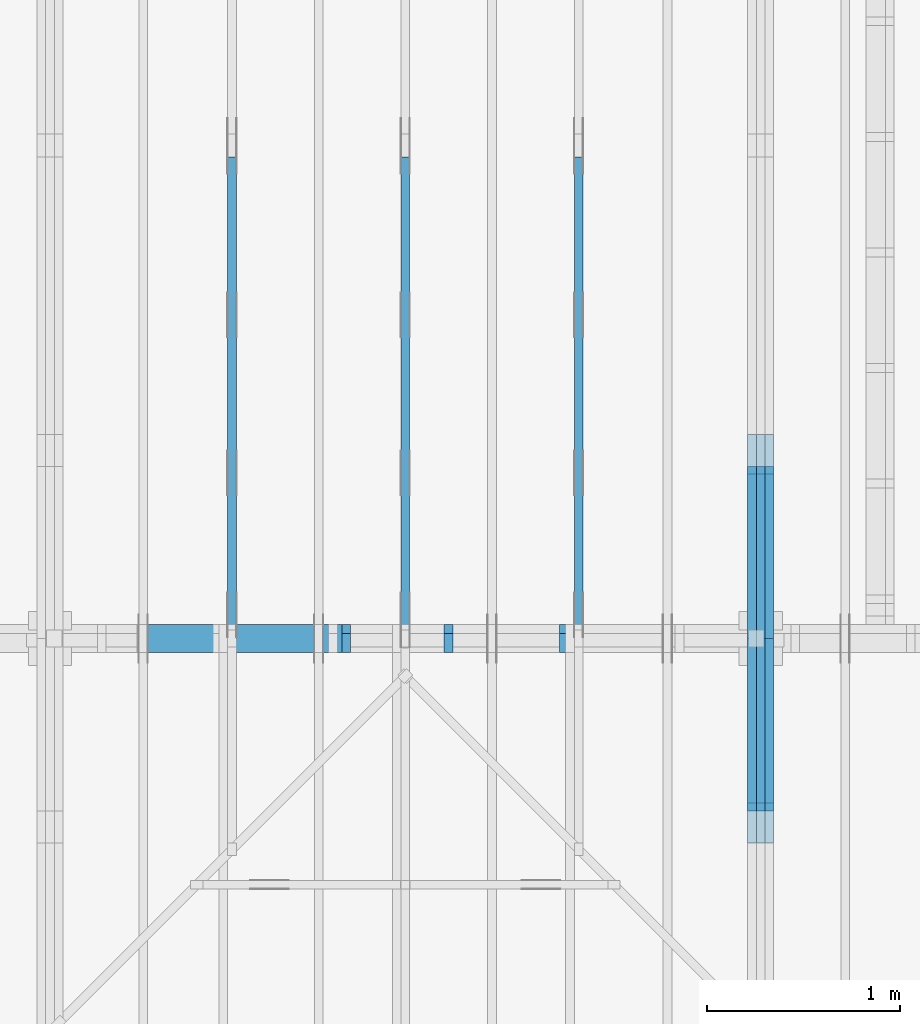
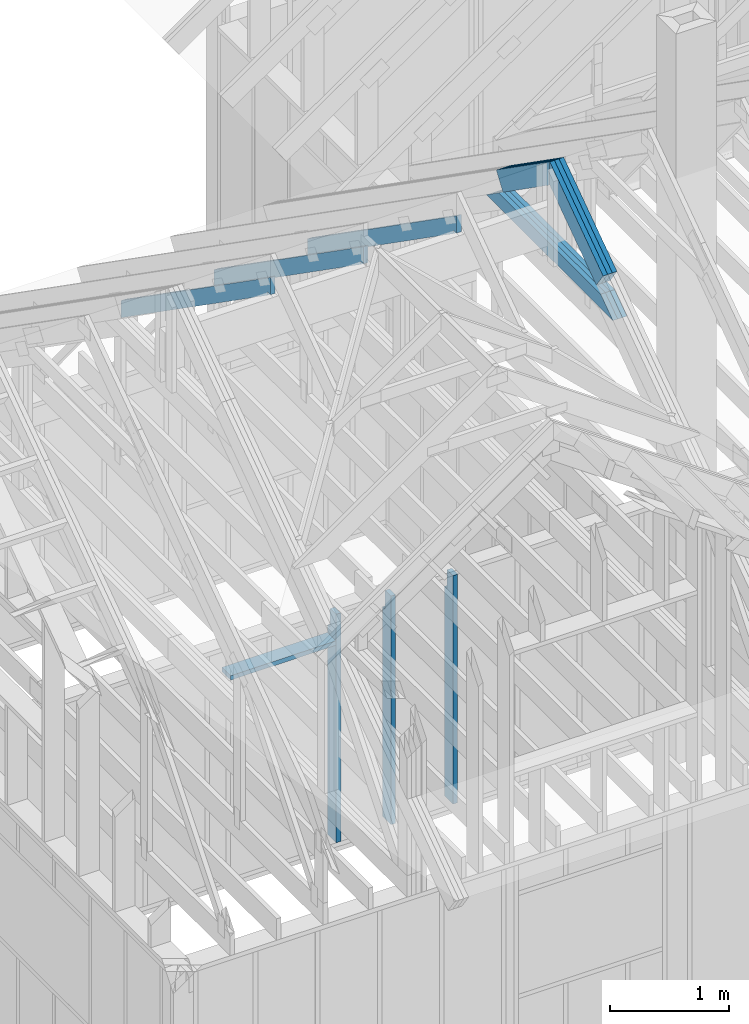
# One storey, part 15 of 70: 16 members, 5 elements without a shape of their own.
"""IFC2X3 building model written with IfcOpenShell, lengths in millimetres."""

from ifc_helpers import new_model, si_unit, frame, origin, origin_with_axes, origin_2d, place, context, project, spatial, faceted_brep, element, aggregate, save


model = new_model("IFC2X3")

# Units and contexts
model_context = context("Model", 3, precision=1e-05, world=origin())
plan_context = context("Plan", 2, precision=1e-05, world=origin_2d())
ifc_project = project(units=[si_unit("LENGTHUNIT", "METRE", prefix="MILLI"), si_unit("AREAUNIT", "SQUARE_METRE"), si_unit("VOLUMEUNIT", "CUBIC_METRE"), si_unit("SOLIDANGLEUNIT", "STERADIAN"), si_unit("PLANEANGLEUNIT", "RADIAN"), si_unit("MASSUNIT", "GRAM"), si_unit("TIMEUNIT", "SECOND"), si_unit("THERMODYNAMICTEMPERATUREUNIT", "DEGREE_CELSIUS"), si_unit("LUMINOUSINTENSITYUNIT", "LUMEN")], contexts=[model_context, plan_context])

# Site, building, storey
site_placement = place(None, origin_with_axes())
site = spatial("IfcSite", under=ifc_project, at=site_placement, CompositionType="ELEMENT")
building_placement = place(site_placement, origin_with_axes())
building = spatial("IfcBuilding", under=site, at=building_placement, Name="Layout 1", CompositionType="ELEMENT")
storey_placement = place(building_placement, origin_with_axes())
storey = spatial("IfcBuildingStorey", under=building, at=storey_placement, Name="Storey 1", CompositionType="ELEMENT", Elevation=0.0)

# Assembly, members
assembly_1_placement = place(storey_placement, frame((5660.000000000293, 8000.0, 9.122500660690286e-13), z_axis=(-1.0, 1.836909530733566e-16, 6.123031769111886e-17), x_axis=(-1.836909530733566e-16, -1.0, 0.0)))
assembly_1 = element("IfcElementAssembly", 1, at=assembly_1_placement, inside=storey, Name="T11", AssemblyPlace="FACTORY", PredefinedType="TRUSS")
member_1_placement = place(assembly_1_placement, frame((3217.6903587327556, 3014.9999999980873, -90.0), z_axis=(0.0, 0.0, 1.0), x_axis=(0.8191520442889916, 0.5735764363510464, 0.0)))
member_1 = element("IfcMember", 2, at=member_1_placement, Name="T18", context=model_context, shape_type="Brep", body=[
    faceted_brep([(1091.564200553914, 195.00000000125283, 45.0), (0.0, 195.00000000125283, 45.0), (8.731149137020111e-11, 0.0, 45.0), (955.0237306050312, 0.0, 45.0), (0.0, 195.00000000125283, 0.0), (1091.564200553914, 195.00000000125283, 1.3367364556033665e-13), (955.0237306050312, 0.0, 1.1695281285500715e-13), (8.731149137020111e-11, 0.0, 1.0692220709365594e-26), (8.731149137020111e-11, 0.0, 0.0), (8.731424673449721e-11, 1.2330791498681715e-27, 45.0), (4.7951469120545665e-14, 195.000000002565, 45.0), (4.5196104824445316e-14, 195.000000002565, -2.7673718568020907e-30), (955.0237306050312, 4.127318893216278e-09, -1.955486371747768e-30), (955.0237306050312, 4.127321648580574e-09, 45.0), (8.73114913702011e-11, 2.7553642961032684e-15, 45.0), (8.731149137020111e-11, 2.9197490389586947e-27, -1.78777161234152e-43), (1091.564200553914, 195.00000000125283, 0.0), (1091.564200553914, 195.00000000125283, 45.0), (955.0237306050312, 4.127286956645548e-09, 45.0), (955.0237306050312, 4.127286956645548e-09, 0.0), (0.0, 195.000000002565, 0.0), (0.0, 195.000000002565, 45.0), (1091.564200553914, 195.00000000125272, 45.0), (1091.564200553914, 195.00000000125272, -6.310887241768095e-30)], [[[0, 1, 2, 3]], [[4, 5, 6, 7]], [[8, 9, 10, 11]], [[12, 13, 14, 15]], [[16, 17, 18, 19]], [[20, 21, 22, 23]]]),
])
member_2_placement = place(assembly_1_placement, frame((3217.6903587327556, 3014.9999999980873, -135.0), z_axis=(0.0, 0.0, 1.0), x_axis=(0.8191520442889916, 0.5735764363510464, 0.0)))
member_2 = element("IfcMember", 3, at=member_2_placement, Name="T18", context=model_context, shape_type="Brep", body=[
    faceted_brep([(1091.564200553914, 195.00000000125283, 45.0), (0.0, 195.00000000125283, 45.0), (8.731149137020111e-11, 0.0, 45.0), (955.0237306050312, 0.0, 45.0), (0.0, 195.00000000125283, 0.0), (1091.564200553914, 195.00000000125283, 1.3367364556033665e-13), (955.0237306050312, 0.0, 1.1695281285500715e-13), (8.731149137020111e-11, 0.0, 1.0692220709365594e-26), (8.731149137020111e-11, 0.0, 0.0), (8.731424673449721e-11, 1.2330791498681715e-27, 45.0), (4.7951469120545665e-14, 195.000000002565, 45.0), (4.5196104824445316e-14, 195.000000002565, -2.7673718568020907e-30), (955.0237306050312, 4.127318893216278e-09, -1.955486371747768e-30), (955.0237306050312, 4.127321648580574e-09, 45.0), (8.73114913702011e-11, 2.7553642961032684e-15, 45.0), (8.731149137020111e-11, 2.9197490389586947e-27, -1.78777161234152e-43), (1091.564200553914, 195.00000000125283, 0.0), (1091.564200553914, 195.00000000125283, 45.0), (955.0237306050312, 4.127286956645548e-09, 45.0), (955.0237306050312, 4.127286956645548e-09, 0.0), (0.0, 195.000000002565, 0.0), (0.0, 195.000000002565, 45.0), (1091.564200553914, 195.00000000125272, 45.0), (1091.564200553914, 195.00000000125272, -6.310887241768095e-30)], [[[0, 1, 2, 3]], [[4, 5, 6, 7]], [[8, 9, 10, 11]], [[12, 13, 14, 15]], [[16, 17, 18, 19]], [[20, 21, 22, 23]]]),
])
member_3_placement = place(assembly_1_placement, frame((3217.6903587327556, 3014.9999999980873, -180.0), z_axis=(0.0, 0.0, 1.0), x_axis=(0.8191520442889916, 0.5735764363510464, 0.0)))
member_3 = element("IfcMember", 4, at=member_3_placement, Name="T18", context=model_context, shape_type="Brep", body=[
    faceted_brep([(1091.564200553914, 195.00000000125283, 45.0), (0.0, 195.00000000125283, 45.0), (8.731149137020111e-11, 0.0, 45.0), (955.0237306050312, 0.0, 45.0), (0.0, 195.00000000125283, 0.0), (1091.564200553914, 195.00000000125283, 1.3367364556033665e-13), (955.0237306050312, 0.0, 1.1695281285500715e-13), (8.731149137020111e-11, 0.0, 1.0692220709365594e-26), (8.731149137020111e-11, 0.0, 0.0), (8.731424673449721e-11, 1.2330791498681715e-27, 45.0), (4.7951469120545665e-14, 195.000000002565, 45.0), (4.5196104824445316e-14, 195.000000002565, -2.7673718568020907e-30), (955.0237306050312, 4.127318893216278e-09, -1.955486371747768e-30), (955.0237306050312, 4.127321648580574e-09, 45.0), (8.73114913702011e-11, 2.7553642961032684e-15, 45.0), (8.731149137020111e-11, 2.9197490389586947e-27, -1.78777161234152e-43), (1091.564200553914, 195.00000000125283, 0.0), (1091.564200553914, 195.00000000125283, 45.0), (955.0237306050312, 4.127286956645548e-09, 45.0), (955.0237306050312, 4.127286956645548e-09, 0.0), (0.0, 195.000000002565, 0.0), (0.0, 195.000000002565, 45.0), (1091.564200553914, 195.00000000125272, 45.0), (1091.564200553914, 195.00000000125272, -6.310887241768095e-30)], [[[0, 1, 2, 3]], [[4, 5, 6, 7]], [[8, 9, 10, 11]], [[12, 13, 14, 15]], [[16, 17, 18, 19]], [[20, 21, 22, 23]]]),
])
member_4_placement = place(assembly_1_placement, frame((3888.1525949105694, 3641.0955042035366, -90.00000000000001), z_axis=(0.0, 0.0, 1.0), x_axis=(0.8191520442889916, -0.5735764363510465, 0.0)))
member_4 = element("IfcMember", 5, at=member_4_placement, Name="T18", context=model_context, shape_type="Brep", body=[
    faceted_brep([(1091.5642005560503, 194.99999999996362, 45.0), (0.0, 194.99999999996362, 45.0), (136.5404699520857, 0.0, 45.0), (1091.5642005561149, 0.0, 45.0), (0.0, 194.99999999996362, 0.0), (1091.5642005560503, 194.99999999996362, 1.336736455605983e-13), (1091.5642005561149, 0.0, 1.336736455606062e-13), (136.5404699520857, 0.0, 1.6720832705721752e-14), (136.54046995208566, -4.263256414560601e-14, 3.1554436208840472e-30), (136.54046995208566, -4.263256414560601e-14, 45.0), (1.4210854715202004e-14, 195.00000000170263, 45.0), (1.4210854715202004e-14, 195.00000000170263, -2.3665827156630354e-30), (1091.5642005561149, 2.0525182992035547e-09, 1.2934457505065866e-29), (1091.5642005561149, 2.0525210545678508e-09, 45.0), (136.5404699520857, -2.3668346958466476e-14, 45.0), (136.5404699520857, -2.6423711254566825e-14, 1.6179322346954286e-30), (1091.5642005561149, 194.99999999996362, 3.950615413346827e-27), (1091.5642005561149, 194.99999999996362, 45.0), (1091.5642005561149, 2.052729541901499e-09, 45.0), (1091.5642005561149, 2.052729541901499e-09, 0.0), (0.0, 195.00000000170257, 0.0), (0.0, 195.00000000170257, 45.0), (1091.5642005560503, 194.9999999999637, 45.0), (1091.5642005560503, 194.9999999999637, 6.310887241768095e-30)], [[[0, 1, 2, 3]], [[4, 5, 6, 7]], [[8, 9, 10, 11]], [[12, 13, 14, 15]], [[16, 17, 18, 19]], [[20, 21, 22, 23]]]),
])
member_5_placement = place(assembly_1_placement, frame((3888.1525949105694, 3641.0955042035366, -135.0), z_axis=(0.0, 0.0, 1.0), x_axis=(0.8191520442889916, -0.5735764363510465, 0.0)))
member_5 = element("IfcMember", 6, at=member_5_placement, Name="T18", context=model_context, shape_type="Brep", body=[
    faceted_brep([(1091.5642005560503, 194.99999999996362, 45.0), (0.0, 194.99999999996362, 45.0), (136.5404699520857, 0.0, 45.0), (1091.5642005561149, 0.0, 45.0), (0.0, 194.99999999996362, 0.0), (1091.5642005560503, 194.99999999996362, 1.336736455605983e-13), (1091.5642005561149, 0.0, 1.336736455606062e-13), (136.5404699520857, 0.0, 1.6720832705721752e-14), (136.54046995208566, -4.263256414560601e-14, 3.1554436208840472e-30), (136.54046995208566, -4.263256414560601e-14, 45.0), (1.4210854715202004e-14, 195.00000000170263, 45.0), (1.4210854715202004e-14, 195.00000000170263, -2.3665827156630354e-30), (1091.5642005561149, 2.0525182992035547e-09, 1.2934457505065866e-29), (1091.5642005561149, 2.0525210545678508e-09, 45.0), (136.5404699520857, -2.3668346958466476e-14, 45.0), (136.5404699520857, -2.6423711254566825e-14, 1.6179322346954286e-30), (1091.5642005561149, 194.99999999996362, 3.950615413346827e-27), (1091.5642005561149, 194.99999999996362, 45.0), (1091.5642005561149, 2.052729541901499e-09, 45.0), (1091.5642005561149, 2.052729541901499e-09, 0.0), (0.0, 195.00000000170257, 0.0), (0.0, 195.00000000170257, 45.0), (1091.5642005560503, 194.9999999999637, 45.0), (1091.5642005560503, 194.9999999999637, 6.310887241768095e-30)], [[[0, 1, 2, 3]], [[4, 5, 6, 7]], [[8, 9, 10, 11]], [[12, 13, 14, 15]], [[16, 17, 18, 19]], [[20, 21, 22, 23]]]),
])
member_6_placement = place(assembly_1_placement, frame((3888.1525949105694, 3641.0955042035366, -180.00000000000003), z_axis=(0.0, 0.0, 1.0), x_axis=(0.8191520442889916, -0.5735764363510465, 0.0)))
member_6 = element("IfcMember", 7, at=member_6_placement, Name="T18", context=model_context, shape_type="Brep", body=[
    faceted_brep([(1091.5642005560503, 194.99999999996362, 45.0), (0.0, 194.99999999996362, 45.0), (136.5404699520857, 0.0, 45.0), (1091.5642005561149, 0.0, 45.0), (0.0, 194.99999999996362, 0.0), (1091.5642005560503, 194.99999999996362, 1.336736455605983e-13), (1091.5642005561149, 0.0, 1.336736455606062e-13), (136.5404699520857, 0.0, 1.6720832705721752e-14), (136.54046995208566, -4.263256414560601e-14, 3.1554436208840472e-30), (136.54046995208566, -4.263256414560601e-14, 45.0), (1.4210854715202004e-14, 195.00000000170263, 45.0), (1.4210854715202004e-14, 195.00000000170263, -2.3665827156630354e-30), (1091.5642005561149, 2.0525182992035547e-09, 1.2934457505065866e-29), (1091.5642005561149, 2.0525210545678508e-09, 45.0), (136.5404699520857, -2.3668346958466476e-14, 45.0), (136.5404699520857, -2.6423711254566825e-14, 1.6179322346954286e-30), (1091.5642005561149, 194.99999999996362, 3.950615413346827e-27), (1091.5642005561149, 194.99999999996362, 45.0), (1091.5642005561149, 2.052729541901499e-09, 45.0), (1091.5642005561149, 2.052729541901499e-09, 0.0), (0.0, 195.00000000170257, 0.0), (0.0, 195.00000000170257, 45.0), (1091.5642005560503, 194.9999999999637, 45.0), (1091.5642005560503, 194.9999999999637, 6.310887241768095e-30)], [[[0, 1, 2, 3]], [[4, 5, 6, 7]], [[8, 9, 10, 11]], [[12, 13, 14, 15]], [[16, 17, 18, 19]], [[20, 21, 22, 23]]]),
])
member_7_placement = place(assembly_1_placement, frame((5060.798502586593, 2964.999999998785, -90.0), z_axis=(0.0, 0.0, 1.0), x_axis=(-1.0, 1.2246063538223773e-16, 0.0)))
member_7 = element("IfcMember", 8, at=member_7_placement, Name="C1", context=model_context, shape_type="Brep", body=[
    faceted_brep([(2121.597005175296, 145.00000000000728, 45.0), (0.0, 145.00000000000728, 45.0), (207.08146097743884, 0.0, 45.0), (1914.5155441979737, 0.0, 45.0), (0.0, 145.00000000000728, 0.0), (2121.597005175296, 145.00000000000728, 2.5981211727881944e-13), (1914.5155441979737, 0.0, 2.3445278999165447e-13), (207.08146097743884, 0.0, 2.5359327287179227e-14), (207.08146097743878, -7.105427357601002e-14, 3.1554436208840472e-30), (207.08146097743878, -7.105427357601002e-14, 45.0), (1.4210854715202004e-14, 145.00000000000728, 45.0), (1.4210854715202004e-14, 145.00000000000728, 0.0), (1914.5155441979737, 7.26803319922997e-12, 4.8521444511629875e-31), (1914.5155441979737, 7.27078856352607e-12, 45.0), (207.08146097743884, 1.898228698049977e-15, 45.0), (207.08146097743884, -8.571355980503717e-16, 5.248268497299439e-32), (2121.597005175296, 145.00000000000728, 0.0), (2121.597005175296, 145.00000000000728, 45.0), (1914.515544197974, 7.389644451905042e-12, 45.0), (1914.515544197974, 7.389644451905042e-12, 1.262177448353619e-29), (0.0, 145.00000000000728, 0.0), (-1.6871183120499046e-31, 145.00000000000728, 45.0), (2121.597005175296, 145.00000000000713, 45.0), (2121.597005175296, 145.00000000000713, -7.888609052210118e-30)], [[[0, 1, 2, 3]], [[4, 5, 6, 7]], [[8, 9, 10, 11]], [[12, 13, 14, 15]], [[16, 17, 18, 19]], [[20, 21, 22, 23]]]),
])
member_8_placement = place(assembly_1_placement, frame((5060.798502586593, 2964.999999998785, -135.0), z_axis=(0.0, 0.0, 1.0), x_axis=(-1.0, 1.2246063538223773e-16, 0.0)))
member_8 = element("IfcMember", 9, at=member_8_placement, Name="C1", context=model_context, shape_type="Brep", body=[
    faceted_brep([(2121.597005175296, 145.00000000000728, 45.0), (0.0, 145.00000000000728, 45.0), (207.08146097743884, 0.0, 45.0), (1914.5155441979737, 0.0, 45.0), (0.0, 145.00000000000728, 0.0), (2121.597005175296, 145.00000000000728, 2.5981211727881944e-13), (1914.5155441979737, 0.0, 2.3445278999165447e-13), (207.08146097743884, 0.0, 2.5359327287179227e-14), (207.08146097743878, -7.105427357601002e-14, 3.1554436208840472e-30), (207.08146097743878, -7.105427357601002e-14, 45.0), (1.4210854715202004e-14, 145.00000000000728, 45.0), (1.4210854715202004e-14, 145.00000000000728, 0.0), (1914.5155441979737, 7.26803319922997e-12, 4.8521444511629875e-31), (1914.5155441979737, 7.27078856352607e-12, 45.0), (207.08146097743884, 1.898228698049977e-15, 45.0), (207.08146097743884, -8.571355980503717e-16, 5.248268497299439e-32), (2121.597005175296, 145.00000000000728, 0.0), (2121.597005175296, 145.00000000000728, 45.0), (1914.515544197974, 7.389644451905042e-12, 45.0), (1914.515544197974, 7.389644451905042e-12, 1.262177448353619e-29), (0.0, 145.00000000000728, 0.0), (-1.6871183120499046e-31, 145.00000000000728, 45.0), (2121.597005175296, 145.00000000000713, 45.0), (2121.597005175296, 145.00000000000713, -7.888609052210118e-30)], [[[0, 1, 2, 3]], [[4, 5, 6, 7]], [[8, 9, 10, 11]], [[12, 13, 14, 15]], [[16, 17, 18, 19]], [[20, 21, 22, 23]]]),
])
member_9_placement = place(assembly_1_placement, frame((5060.798502586593, 2964.999999998785, -180.0), z_axis=(0.0, 0.0, 1.0), x_axis=(-1.0, 1.2246063538223773e-16, 0.0)))
member_9 = element("IfcMember", 10, at=member_9_placement, Name="C1", context=model_context, shape_type="Brep", body=[
    faceted_brep([(2121.597005175296, 145.00000000000728, 45.0), (0.0, 145.00000000000728, 45.0), (207.08146097743884, 0.0, 45.0), (1914.5155441979737, 0.0, 45.0), (0.0, 145.00000000000728, 0.0), (2121.597005175296, 145.00000000000728, 2.5981211727881944e-13), (1914.5155441979737, 0.0, 2.3445278999165447e-13), (207.08146097743884, 0.0, 2.5359327287179227e-14), (207.08146097743878, -7.105427357601002e-14, 3.1554436208840472e-30), (207.08146097743878, -7.105427357601002e-14, 45.0), (1.4210854715202004e-14, 145.00000000000728, 45.0), (1.4210854715202004e-14, 145.00000000000728, 0.0), (1914.5155441979737, 7.26803319922997e-12, 4.8521444511629875e-31), (1914.5155441979737, 7.27078856352607e-12, 45.0), (207.08146097743884, 1.898228698049977e-15, 45.0), (207.08146097743884, -8.571355980503717e-16, 5.248268497299439e-32), (2121.597005175296, 145.00000000000728, 0.0), (2121.597005175296, 145.00000000000728, 45.0), (1914.515544197974, 7.389644451905042e-12, 45.0), (1914.515544197974, 7.389644451905042e-12, 1.262177448353619e-29), (0.0, 145.00000000000728, 0.0), (-1.6871183120499046e-31, 145.00000000000728, 45.0), (2121.597005175296, 145.00000000000713, 45.0), (2121.597005175296, 145.00000000000713, -7.888609052210118e-30)], [[[0, 1, 2, 3]], [[4, 5, 6, 7]], [[8, 9, 10, 11]], [[12, 13, 14, 15]], [[16, 17, 18, 19]], [[20, 21, 22, 23]]]),
])
aggregate(assembly_1, [member_1, member_2, member_3, member_4, member_5, member_6, member_7, member_8, member_9])

assembly_2_placement = place(storey_placement, frame((-48.55339059327651, 3927.500000000001, -2470.0), z_axis=(0.0, -1.0, 6.123031769111886e-17), x_axis=(1.0, 0.0, 0.0)))
assembly_2 = element("IfcElementAssembly", 11, at=assembly_2_placement, inside=storey, Name="VE8", AssemblyPlace="FACTORY", PredefinedType="NOTDEFINED")
member_10_placement = place(assembly_2_placement, frame((4177.5000000018335, 2425.0, -145.00000000000003), z_axis=(0.0, 0.0, 1.0), x_axis=(-1.836909530733566e-16, -1.0, 0.0)))
member_10 = element("IfcMember", 12, at=member_10_placement, Name="S42", context=model_context, shape_type="Brep", body=[
    faceted_brep([(0.0, 45.00000000001455, 45.00000000000003), (195.00000000186265, 45.00000000001455, 45.00000000000005), (195.00000000186265, 0.0, 45.00000000000005), (0.0, 0.0, 45.00000000000003), (195.00000000186265, -2.1311460639909362e-46, 2.842170943040401e-14), (195.00000000186265, -3.3742366240998114e-31, 45.00000000000003), (195.00000000186265, 45.00000000001182, 45.00000000000003), (195.00000000186265, 45.00000000001182, 2.842170943040401e-14), (2.7553642961003504e-15, -3.3742366240998114e-31, 45.00000000000003), (8.878396065212235e-15, -1.0872540233210496e-30, 145.0), (1.4389124657414716e-14, 45.00000000001455, 145.00000000000003), (8.26609288830283e-15, 45.00000000001455, 45.00000000000003), (2335.0, -4.2891837542628763e-13, 2.842170943040403e-14), (2335.0, -4.200399793610754e-13, 145.00000000000003), (1.6308810349815748e-30, 8.878396065212237e-15, 145.00000000000003), (5.061354936149717e-31, 2.7553642961003504e-15, 45.00000000000003), (195.00000000186265, -3.306437155354634e-14, 45.00000000000003), (195.00000000186265, -3.5819735849646686e-14, 2.842170943040401e-14), (-1.6871183120499057e-31, 45.00000000001182, 45.00000000000003), (-5.436270116605249e-31, 45.000000000011816, 145.00000000000003), (2335.0, 45.000000000011674, 145.00000000000003), (2335.0, 45.00000000001168, 2.8421709430403998e-14), (195.00000000186265, 45.00000000001181, 2.8421709430404004e-14), (195.00000000186265, 45.00000000001181, 45.00000000000003), (2335.0, 44.99999999998545, 0.0), (2335.0, 44.99999999998545, 145.00000000000003), (2335.0, 0.0, 145.00000000000003), (2335.0, 0.0, 0.0), (2335.0, 44.99999999998545, 145.00000000000003), (0.0, 44.99999999998545, 145.00000000000003), (0.0, 0.0, 145.00000000000003), (2335.0, 0.0, 145.00000000000003), (195.00000000186265, 45.00000000001182, 5.2301533330168465e-14), (2335.0, 45.00000000001182, 3.143672930479291e-13), (2335.0, 0.0, 3.143672930479291e-13), (195.00000000186265, 0.0, 5.2301533330168465e-14)], [[[0, 1, 2, 3]], [[4, 5, 6, 7]], [[8, 9, 10, 11]], [[12, 13, 14, 15, 16, 17]], [[18, 19, 20, 21, 22, 23]], [[24, 25, 26, 27]], [[28, 29, 30, 31]], [[32, 33, 34, 35]]]),
])
member_11_placement = place(assembly_2_placement, frame((4777.5000000018335, 2425.0, -145.00000000000003), z_axis=(0.0, 0.0, 1.0), x_axis=(-1.836909530733566e-16, -1.0, 0.0)))
member_11 = element("IfcMember", 13, at=member_11_placement, Name="S42", context=model_context, shape_type="Brep", body=[
    faceted_brep([(0.0, 45.0, 45.00000000000003), (195.00000000186265, 45.0, 45.00000000000005), (195.00000000186265, 1.4551915228366852e-11, 45.00000000000005), (0.0, 1.4551915228366852e-11, 45.00000000000003), (195.00000000186265, 1.3642420526593924e-11, 2.842170943040401e-14), (195.00000000186265, 1.3642420526593924e-11, 45.00000000000003), (195.00000000186265, 44.99999999999909, 45.00000000000003), (195.00000000186265, 44.99999999999909, 2.842170943040401e-14), (2.7553642961021324e-15, 1.4551915228366852e-11, 45.00000000000003), (8.878396065214018e-15, 1.4551915228366852e-11, 145.00000000000003), (1.4389124657412933e-14, 45.0, 145.00000000000003), (8.266092888301048e-15, 45.0, 45.00000000000003), (2335.0, 1.4122996852940564e-11, 2.842170943040403e-14), (2335.0, 1.4131875249005776e-11, 145.00000000000003), (1.6308810349815748e-30, 1.4560793624432064e-11, 145.00000000000003), (5.061354936149717e-31, 1.4554670592662952e-11, 45.00000000000003), (195.00000000186265, 1.4518850856813305e-11, 45.00000000000003), (195.00000000186265, 1.4516095492517205e-11, 2.8421709430404014e-14), (-1.6871183120499057e-31, 44.99999999999909, 45.00000000000003), (-5.436270116605249e-31, 44.99999999999908, 145.00000000000003), (2335.0, 44.99999999999894, 145.00000000000003), (2335.0, 44.99999999999895, 2.8421709430403998e-14), (195.00000000186265, 44.999999999999076, 2.8421709430404004e-14), (195.00000000186265, 44.999999999999076, 45.00000000000003), (2335.0, 44.99999999998545, 0.0), (2335.0, 44.99999999998545, 145.00000000000003), (2335.0, 0.0, 145.00000000000003), (2335.0, 0.0, 0.0), (2335.0, 44.99999999998545, 145.00000000000003), (0.0, 44.99999999998545, 145.00000000000003), (0.0, 1.4551915228366852e-11, 145.00000000000003), (2335.0, 1.4551915228366852e-11, 145.00000000000003), (195.00000000186265, 44.99999999999909, 5.2301533330168465e-14), (2335.0, 44.99999999999909, 3.143672930479291e-13), (2335.0, 0.0, 3.143672930479291e-13), (195.00000000186265, 0.0, 5.2301533330168465e-14)], [[[0, 1, 2, 3]], [[4, 5, 6, 7]], [[8, 9, 10, 11]], [[12, 13, 14, 15, 16, 17]], [[18, 19, 20, 21, 22, 23]], [[24, 25, 26, 27]], [[28, 29, 30, 31]], [[32, 33, 34, 35]]]),
])
member_12_placement = place(assembly_2_placement, frame((3647.3033905951015, 2425.0, -145.0), z_axis=(0.0, 0.0, 1.0), x_axis=(-1.836909530733566e-16, -1.0, 0.0)))
member_12 = element("IfcMember", 14, at=member_12_placement, Name="S42", context=model_context, shape_type="Brep", body=[
    faceted_brep([(0.0, 45.00000000001455, 45.0), (195.00000000186265, 45.00000000001455, 45.00000000000002), (195.00000000186265, 0.0, 45.00000000000002), (0.0, 0.0, 45.0), (195.00000000186265, 0.0, 0.0), (195.00000000186265, -3.3742366240998092e-31, 45.0), (195.00000000186265, 45.00000000001455, 45.0), (195.00000000186265, 45.00000000001455, 0.0), (2.755364296100349e-15, -3.3742366240998092e-31, 45.0), (8.878396065212235e-15, -1.0872540233210496e-30, 145.0), (1.4389124657414716e-14, 45.00000000001455, 145.0), (8.26609288830283e-15, 45.00000000001455, 45.0), (2335.0, -4.2891837542628763e-13, 2.626280839091018e-29), (2335.0, -4.200399793610754e-13, 145.0), (1.6308810349815745e-30, 8.878396065212235e-15, 145.0), (5.061354936149714e-31, 2.755364296100349e-15, 45.0), (195.00000000186265, -3.306437155354634e-14, 45.0), (195.00000000186265, -3.5819735849646686e-14, 2.193253805685826e-30), (-1.6871183120499046e-31, 45.00000000001455, 45.0), (-5.436270116605248e-31, 45.000000000014545, 145.0), (2335.0, 45.0000000000144, 145.0), (2335.0, 45.00000000001441, -8.67746995743113e-30), (195.00000000186265, 45.00000000001454, -7.888609052210118e-31), (195.00000000186265, 45.00000000001454, 45.0), (2335.0, 45.00000000001501, 2.842170943040401e-14), (2335.0, 45.00000000001501, 145.0), (2335.0, 4.547473508864641e-13, 145.0), (2335.0, 4.547473508864641e-13, 2.842170943040401e-14), (2335.0, 45.00000000001501, 145.0), (0.0, 45.00000000001501, 145.0), (0.0, 0.0, 145.0), (2335.0, 0.0, 145.0), (195.00000000186265, 45.00000000001455, 2.3879823899764457e-14), (2335.0, 45.00000000001455, 2.859455836175251e-13), (2335.0, 4.547473508864641e-13, 2.859455836175251e-13), (195.00000000186265, 4.547473508864641e-13, 2.3879823899764457e-14)], [[[0, 1, 2, 3]], [[4, 5, 6, 7]], [[8, 9, 10, 11]], [[12, 13, 14, 15, 16, 17]], [[18, 19, 20, 21, 22, 23]], [[24, 25, 26, 27]], [[28, 29, 30, 31]], [[32, 33, 34, 35]]]),
])
member_13_placement = place(assembly_2_placement, frame((3647.3033905932766, 2154.9999999987776, -145.0), z_axis=(0.0, 0.0, 1.0), x_axis=(-1.0, 1.2246063538223773e-16, 0.0)))
member_13 = element("IfcMember", 15, at=member_13_placement, Name="S45", context=model_context, shape_type="Brep", body=[
    faceted_brep([(1020.0, 45.00000000001455, 145.0), (0.0, 45.00000000001455, 145.0), (0.0, 0.0, 145.0), (1020.0, 0.0, 145.0), (0.0, 45.00000000001455, 0.0), (1020.0, 45.00000000001455, 1.2490984808988248e-13), (1020.0, 0.0, 1.2490984808988248e-13), (0.0, 0.0, 0.0), (0.0, 0.0, 0.0), (8.878396065212235e-15, -1.0872540233210496e-30, 145.0), (1.4389124657414716e-14, 45.00000000001455, 145.0), (5.51072859220248e-15, 45.00000000001455, -3.3742366241009005e-31), (1020.0, -1.8736477213482372e-13, 1.1472404521939351e-29), (1020.0, -1.7848637606961149e-13, 145.0), (1.6308810349815745e-30, 8.878396065212235e-15, 145.0), (0.0, 0.0, 0.0), (1020.0, 45.00000000001455, 0.0), (1020.0, 45.00000000001455, 145.0), (1020.0, 0.0, 145.0), (1020.0, 0.0, 0.0), (-1.2154326714572542e-63, 45.00000000001455, 0.0), (-5.436270116605248e-31, 45.000000000014545, 145.0), (1020.0, 45.00000000001448, 145.0), (1020.0, 45.00000000001449, -3.944304526105059e-30)], [[[0, 1, 2, 3]], [[4, 5, 6, 7]], [[8, 9, 10, 11]], [[12, 13, 14, 15]], [[16, 17, 18, 19]], [[20, 21, 22, 23]]]),
])
aggregate(assembly_2, [member_10, member_11, member_12, member_13])

# Assembly, member
assembly_3_placement = place(storey_placement, frame((4805.0, 8000.000000000001, -4.5336966873841394e-13), z_axis=(-1.0, 1.836909530733566e-16, 6.123031769111886e-17), x_axis=(-1.836909530733566e-16, -1.0, 0.0)))
assembly_3 = element("IfcElementAssembly", 16, at=assembly_3_placement, inside=storey, Name="T1", AssemblyPlace="FACTORY", PredefinedType="TRUSS")
member_14_placement = place(assembly_3_placement, frame((1500.0000000016166, 1635.2479471356055, -45.00000000000001), z_axis=(0.0, 0.0, 1.0), x_axis=(0.819152044289039, 0.5735764363509788, 0.0)))
member_14 = element("IfcMember", 17, at=member_14_placement, Name="SC1", context=model_context, shape_type="Brep", body=[
    faceted_brep([(3153.466564941884, 145.00000000001808, 45.0), (101.53009304063289, 145.00000000001808, 45.0), (0.0, 0.0, 45.0), (2993.339291642151, 0.0, 45.0), (3012.6171737768436, 27.53166894659796, 45.0), (3051.9364719027108, 0.0, 45.0), (101.53009304063289, 145.00000000001808, 1.2433439704173617e-14), (3153.466564941884, 145.00000000001808, 3.861755191994257e-13), (3051.9364719027108, 0.0, 3.737420794954309e-13), (3012.6171737768436, 27.53166894659796, 3.6892701326415355e-13), (2993.339291642151, 0.0, 3.665662315691152e-13), (0.0, 0.0, 0.0), (101.53009304063289, 144.99999999999397, 0.0), (101.53009304063289, 144.99999999999397, 45.0), (3153.466564941884, 145.0000000000182, 45.0), (3153.466564941884, 145.0000000000182, 6.310887241768095e-30), (1.1640850691042934e-14, -8.151011405060374e-15, -8.701351488741532e-31), (1.3897912986952758e-14, -9.731423438868915e-15, 45.0), (101.53009304063293, 144.99999999999397, 45.0), (101.53009304063293, 144.99999999999397, -2.4478569593161768e-30), (2993.339291642151, 1.7222354970193538e-09, -4.137414620662534e-29), (2993.339291642151, 1.7222382523836499e-09, 45.0), (-1.5853151733295292e-27, 2.755364296100349e-15, 45.0), (0.0, 0.0, 0.0), (3012.6171737768445, 27.53166894659762, 7.573064690121713e-29), (3012.6171737768445, 27.53166894659762, 45.0), (2993.3392916421517, 1.7212187231052667e-09, 45.0), (2993.3392916421517, 1.7212187231052667e-09, 7.573064690121713e-29), (3051.9364719027103, 1.754870027070865e-09, 6.310887241768094e-29), (3051.9364719027103, 1.754870027070865e-09, 45.0), (3012.617173776843, 27.531668946597165, 45.0), (3012.617173776843, 27.531668946597165, 6.310887241768094e-29), (3153.4665649418857, 145.0000000000175, 1.0097419586828951e-28), (3153.4665649418857, 145.0000000000175, 45.0), (3051.936471902712, 1.7550974007463083e-09, 45.0), (3051.936471902712, 1.7550974007463083e-09, 1.0097419586828951e-28)], [[[0, 1, 2, 3, 4, 5]], [[6, 7, 8, 9, 10, 11]], [[12, 13, 14, 15]], [[16, 17, 18, 19]], [[20, 21, 22, 23]], [[24, 25, 26, 27]], [[28, 29, 30, 31]], [[32, 33, 34, 35]]]),
])
aggregate(assembly_3, [member_14])

assembly_4_placement = place(storey_placement, frame((3905.0000000000005, 8000.000000000001, -4.5336966873841394e-13), z_axis=(-1.0, 1.836909530733566e-16, 6.123031769111886e-17), x_axis=(-1.836909530733566e-16, -1.0, 0.0)))
assembly_4 = element("IfcElementAssembly", 18, at=assembly_4_placement, inside=storey, Name="T1", AssemblyPlace="FACTORY", PredefinedType="TRUSS")
member_15_placement = place(assembly_4_placement, frame((1500.0000000016166, 1635.2479471356055, -45.00000000000001), z_axis=(0.0, 0.0, 1.0), x_axis=(0.819152044289039, 0.5735764363509788, 0.0)))
member_15 = element("IfcMember", 19, at=member_15_placement, Name="SC1", context=model_context, shape_type="Brep", body=[
    faceted_brep([(3153.466564941884, 145.00000000001808, 45.0), (101.53009304063289, 145.00000000001808, 45.0), (0.0, 0.0, 45.0), (2993.339291642151, 0.0, 45.0), (3012.6171737768436, 27.53166894659796, 45.0), (3051.9364719027108, 0.0, 45.0), (101.53009304063289, 145.00000000001808, 1.2433439704173617e-14), (3153.466564941884, 145.00000000001808, 3.861755191994257e-13), (3051.9364719027108, 0.0, 3.737420794954309e-13), (3012.6171737768436, 27.53166894659796, 3.6892701326415355e-13), (2993.339291642151, 0.0, 3.665662315691152e-13), (0.0, 0.0, 0.0), (101.53009304063289, 144.99999999999397, 0.0), (101.53009304063289, 144.99999999999397, 45.0), (3153.466564941884, 145.0000000000182, 45.0), (3153.466564941884, 145.0000000000182, 6.310887241768095e-30), (1.1640850691042934e-14, -8.151011405060374e-15, -8.701351488741532e-31), (1.3897912986952758e-14, -9.731423438868915e-15, 45.0), (101.53009304063293, 144.99999999999397, 45.0), (101.53009304063293, 144.99999999999397, -2.4478569593161768e-30), (2993.339291642151, 1.7222354970193538e-09, -4.137414620662534e-29), (2993.339291642151, 1.7222382523836499e-09, 45.0), (-1.5853151733295292e-27, 2.755364296100349e-15, 45.0), (0.0, 0.0, 0.0), (3012.6171737768445, 27.53166894659762, 7.573064690121713e-29), (3012.6171737768445, 27.53166894659762, 45.0), (2993.3392916421517, 1.7212187231052667e-09, 45.0), (2993.3392916421517, 1.7212187231052667e-09, 7.573064690121713e-29), (3051.9364719027103, 1.754870027070865e-09, 6.310887241768094e-29), (3051.9364719027103, 1.754870027070865e-09, 45.0), (3012.617173776843, 27.531668946597165, 45.0), (3012.617173776843, 27.531668946597165, 6.310887241768094e-29), (3153.4665649418857, 145.0000000000175, 1.0097419586828951e-28), (3153.4665649418857, 145.0000000000175, 45.0), (3051.936471902712, 1.7550974007463083e-09, 45.0), (3051.936471902712, 1.7550974007463083e-09, 1.0097419586828951e-28)], [[[0, 1, 2, 3, 4, 5]], [[6, 7, 8, 9, 10, 11]], [[12, 13, 14, 15]], [[16, 17, 18, 19]], [[20, 21, 22, 23]], [[24, 25, 26, 27]], [[28, 29, 30, 31]], [[32, 33, 34, 35]]]),
])
aggregate(assembly_4, [member_15])

assembly_5_placement = place(storey_placement, frame((3005.0000000000005, 8000.0, 1.3776821480501744e-15), z_axis=(-1.0, 1.836909530733566e-16, 6.123031769111886e-17), x_axis=(-1.836909530733566e-16, -1.0, 0.0)))
assembly_5 = element("IfcElementAssembly", 20, at=assembly_5_placement, inside=storey, Name="T1", AssemblyPlace="FACTORY", PredefinedType="TRUSS")
member_16_placement = place(assembly_5_placement, frame((1500.0000000016166, 1635.2479471356055, -45.00000000000001), z_axis=(0.0, 0.0, 1.0), x_axis=(0.819152044289039, 0.5735764363509788, 0.0)))
member_16 = element("IfcMember", 21, at=member_16_placement, Name="SC1", context=model_context, shape_type="Brep", body=[
    faceted_brep([(3153.466564941884, 145.00000000001808, 45.0), (101.53009304063289, 145.00000000001808, 45.0), (0.0, 0.0, 45.0), (2993.339291642151, 0.0, 45.0), (3012.6171737768436, 27.53166894659796, 45.0), (3051.9364719027108, 0.0, 45.0), (101.53009304063289, 145.00000000001808, 1.2433439704173617e-14), (3153.466564941884, 145.00000000001808, 3.861755191994257e-13), (3051.9364719027108, 0.0, 3.737420794954309e-13), (3012.6171737768436, 27.53166894659796, 3.6892701326415355e-13), (2993.339291642151, 0.0, 3.665662315691152e-13), (0.0, 0.0, 0.0), (101.53009304063289, 144.99999999999397, 0.0), (101.53009304063289, 144.99999999999397, 45.0), (3153.466564941884, 145.0000000000182, 45.0), (3153.466564941884, 145.0000000000182, 6.310887241768095e-30), (1.1640850691042934e-14, -8.151011405060374e-15, -8.701351488741532e-31), (1.3897912986952758e-14, -9.731423438868915e-15, 45.0), (101.53009304063293, 144.99999999999397, 45.0), (101.53009304063293, 144.99999999999397, -2.4478569593161768e-30), (2993.339291642151, 1.7222354970193538e-09, -4.137414620662534e-29), (2993.339291642151, 1.7222382523836499e-09, 45.0), (-1.5853151733295292e-27, 2.755364296100349e-15, 45.0), (0.0, 0.0, 0.0), (3012.6171737768445, 27.53166894659762, 7.573064690121713e-29), (3012.6171737768445, 27.53166894659762, 45.0), (2993.3392916421517, 1.7212187231052667e-09, 45.0), (2993.3392916421517, 1.7212187231052667e-09, 7.573064690121713e-29), (3051.9364719027103, 1.754870027070865e-09, 6.310887241768094e-29), (3051.9364719027103, 1.754870027070865e-09, 45.0), (3012.617173776843, 27.531668946597165, 45.0), (3012.617173776843, 27.531668946597165, 6.310887241768094e-29), (3153.4665649418857, 145.0000000000175, 1.0097419586828951e-28), (3153.4665649418857, 145.0000000000175, 45.0), (3051.936471902712, 1.7550974007463083e-09, 45.0), (3051.936471902712, 1.7550974007463083e-09, 1.0097419586828951e-28)], [[[0, 1, 2, 3, 4, 5]], [[6, 7, 8, 9, 10, 11]], [[12, 13, 14, 15]], [[16, 17, 18, 19]], [[20, 21, 22, 23]], [[24, 25, 26, 27]], [[28, 29, 30, 31]], [[32, 33, 34, 35]]]),
])
aggregate(assembly_5, [member_16])

save(model, "model.ifc")
